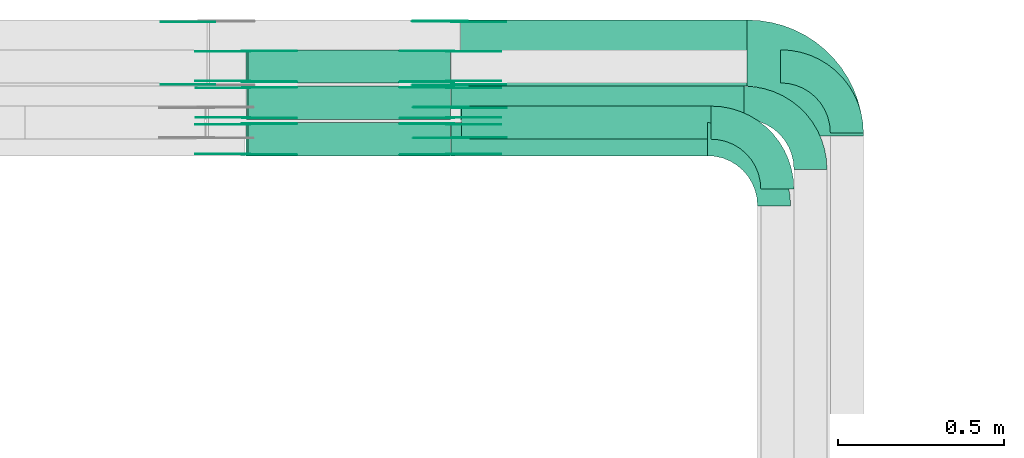
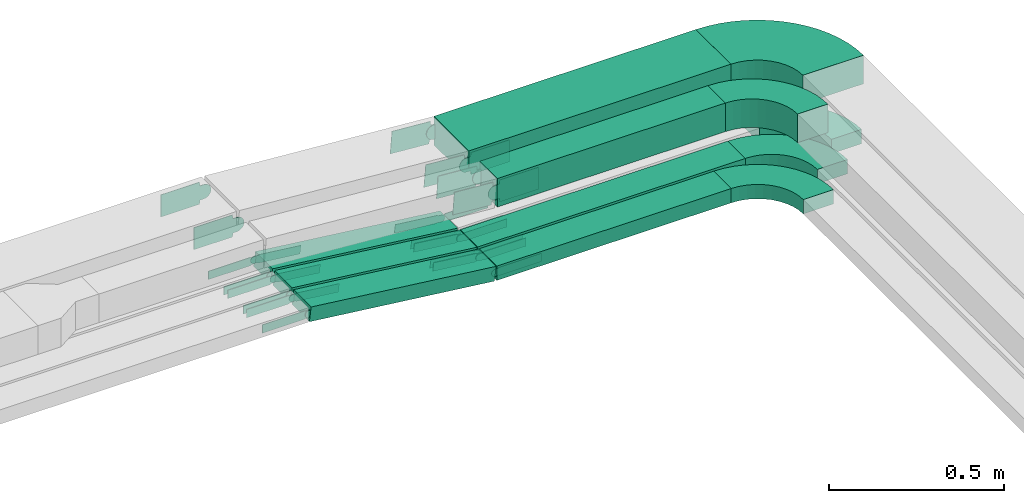
# One storey, part 22 of 23: 39 flow fittings, 7 flow segments.
"""IFC2X3 building model written with IfcOpenShell, lengths in millimetres."""

from ifc_helpers import new_model, entity, si_unit, converted_unit, derived_unit, direction, frame, frame_2d, origin, origin_2d_with_axis, place, context, subcontext, project, spatial, polyline, circle_curve, parameter, trimmed, segment, composite_curve, rectangle, outline, extrude, source, transform, mapped, material, type_object, type_shapes, element, save


model = new_model("IFC2X3")

# Units and contexts
model_context = context("Model", 3, precision=0.01, world=origin(), true_north=direction((6.12303176911189e-17, 1.0)))
body_context = subcontext(model_context, "Body", "Model", "MODEL_VIEW")
ifc_project = project(units=[si_unit("LENGTHUNIT", "METRE", prefix="MILLI"), si_unit("AREAUNIT", "SQUARE_METRE"), si_unit("VOLUMEUNIT", "CUBIC_METRE"), converted_unit("PLANEANGLEUNIT", "DEGREE", entity("IfcRatioMeasure", 0.0174532925199433), si_unit("PLANEANGLEUNIT", "RADIAN"), dimensions=[0, 0, 0, 0, 0, 0, 0]), si_unit("MASSUNIT", "GRAM", prefix="KILO"), derived_unit("MASSDENSITYUNIT", [(si_unit("MASSUNIT", "GRAM", prefix="KILO"), 1), (si_unit("LENGTHUNIT", "METRE"), -3)]), derived_unit("MOMENTOFINERTIAUNIT", [(si_unit("LENGTHUNIT", "METRE"), 4)]), si_unit("TIMEUNIT", "SECOND"), si_unit("FREQUENCYUNIT", "HERTZ"), si_unit("THERMODYNAMICTEMPERATUREUNIT", "DEGREE_CELSIUS"), derived_unit("THERMALTRANSMITTANCEUNIT", [(si_unit("MASSUNIT", "GRAM", prefix="KILO"), 1), (si_unit("THERMODYNAMICTEMPERATUREUNIT", "KELVIN"), -1), (si_unit("TIMEUNIT", "SECOND"), -3)]), derived_unit("VOLUMETRICFLOWRATEUNIT", [(si_unit("LENGTHUNIT", "METRE"), 3), (si_unit("TIMEUNIT", "SECOND"), -1)]), derived_unit("MASSFLOWRATEUNIT", [(si_unit("MASSUNIT", "GRAM", prefix="KILO"), 1), (si_unit("TIMEUNIT", "SECOND"), -1)]), derived_unit("ROTATIONALFREQUENCYUNIT", [(si_unit("TIMEUNIT", "SECOND"), -1)]), si_unit("ELECTRICCURRENTUNIT", "AMPERE"), si_unit("ELECTRICVOLTAGEUNIT", "VOLT"), si_unit("POWERUNIT", "WATT"), si_unit("FORCEUNIT", "NEWTON", prefix="KILO"), si_unit("ILLUMINANCEUNIT", "LUX"), si_unit("LUMINOUSFLUXUNIT", "LUMEN"), si_unit("LUMINOUSINTENSITYUNIT", "CANDELA"), derived_unit("USERDEFINED", [(si_unit("MASSUNIT", "GRAM", prefix="KILO"), -1), (si_unit("LENGTHUNIT", "METRE"), -2), (si_unit("TIMEUNIT", "SECOND"), 3), (si_unit("LUMINOUSFLUXUNIT", "LUMEN"), 1)]), derived_unit("LINEARVELOCITYUNIT", [(si_unit("LENGTHUNIT", "METRE"), 1), (si_unit("TIMEUNIT", "SECOND"), -1)]), si_unit("PRESSUREUNIT", "PASCAL"), derived_unit("USERDEFINED", [(si_unit("LENGTHUNIT", "METRE"), -2), (si_unit("MASSUNIT", "GRAM", prefix="KILO"), 1), (si_unit("TIMEUNIT", "SECOND"), -2)]), derived_unit("LINEARFORCEUNIT", [(si_unit("MASSUNIT", "GRAM", prefix="KILO"), 1), (si_unit("LENGTHUNIT", "METRE"), 1), (si_unit("TIMEUNIT", "SECOND"), -2), (si_unit("LENGTHUNIT", "METRE"), -1)]), derived_unit("PLANARFORCEUNIT", [(si_unit("MASSUNIT", "GRAM", prefix="KILO"), 1), (si_unit("LENGTHUNIT", "METRE"), 1), (si_unit("TIMEUNIT", "SECOND"), -2), (si_unit("LENGTHUNIT", "METRE"), -2)])], contexts=[model_context])

# Site, building, storey
site_placement = place(None, origin())
site = spatial("IfcSite", under=ifc_project, at=site_placement, CompositionType="ELEMENT")
building_placement = place(site_placement, origin())
building = spatial("IfcBuilding", under=site, at=building_placement, CompositionType="ELEMENT")
storey_placement = place(building_placement, frame((0.0, 0.0, 24000.0)))
storey = spatial("IfcBuildingStorey", under=building, at=storey_placement, CompositionType="ELEMENT", Elevation=24000.0)

# Flow segments
cable_carrier_segment_type = type_object("IfcCableCarrierSegmentType", PredefinedType="CABLETRAYSEGMENT")
flow_segment_1_placement = place(storey_placement, frame((63984.79, 18810.0, 2972.83)))
element("IfcFlowSegment", 1, at=flow_segment_1_placement, inside=storey, type_object=cable_carrier_segment_type, context=body_context, shape_type="SweptSolid", body=[
    extrude(rectangle(XDim=884.28828783733, YDim=99.9999999999989, at=origin_2d_with_axis()), frame((442.14, 50.0, 0.0), z_axis=(0.0, 0.0, 1.0), x_axis=(-1.0, 0.0, 0.0)), (0.0, 0.0, 1.0), 49.9999999999973),
])
flow_segment_2_placement = place(storey_placement, frame((63984.79, 18700.0, 2972.83)))
element("IfcFlowSegment", 2, at=flow_segment_2_placement, inside=storey, type_object=cable_carrier_segment_type, context=body_context, shape_type="SweptSolid", body=[
    extrude(rectangle(XDim=774.292459002087, YDim=99.9999999999989, at=origin_2d_with_axis()), frame((387.15, 50.0, 0.0), z_axis=(0.0, 0.0, 1.0), x_axis=(-1.0, 0.0, 0.0)), (0.0, 0.0, 1.0), 49.9999999999973),
])
flow_segment_3_placement = place(storey_placement, frame((64013.12, 18910.0, 3187.83)))
element("IfcFlowSegment", 3, at=flow_segment_3_placement, inside=storey, type_object=cable_carrier_segment_type, context=body_context, shape_type="SweptSolid", body=[
    extrude(rectangle(XDim=865.961742419888, YDim=199.999999999998, at=origin_2d_with_axis()), frame((432.98, 100.0, 0.0), z_axis=(0.0, 0.0, 1.0), x_axis=(-1.0, 0.0, 0.0)), (0.0, 0.0, 1.0), 100.000000000003),
])
flow_segment_4_placement = place(storey_placement, frame((64015.61, 18750.0, 3187.83)))
element("IfcFlowSegment", 4, at=flow_segment_4_placement, inside=storey, type_object=cable_carrier_segment_type, context=body_context, shape_type="SweptSolid", body=[
    extrude(rectangle(XDim=753.47142261159, YDim=99.9999999999989, at=origin_2d_with_axis()), frame((376.74, 50.0, 0.0), z_axis=(0.0, 0.0, 1.0), x_axis=(-1.0, 0.0, 0.0)), (0.0, 0.0, 1.0), 100.000000000003),
])
flow_segment_5_placement = place(storey_placement, frame((63365.28, 18700.0, 2973.31)))
element("IfcFlowSegment", 5, at=flow_segment_5_placement, inside=storey, type_object=cable_carrier_segment_type, context=body_context, shape_type="SweptSolid", body=[
    extrude(rectangle(XDim=49.9999999999981, YDim=99.9999999999989, at=origin_2d_with_axis()), frame((2.92, 50.0, 96.77), z_axis=(0.993143370179474, 0.0, -0.116902721390724), x_axis=(0.116902721390724, 0.0, 0.993143370179474)), (0.0, 0.0, 1.0), 615.423397465658),
])
flow_segment_6_placement = place(storey_placement, frame((63366.23, 18810.0, 2973.32)))
element("IfcFlowSegment", 6, at=flow_segment_6_placement, inside=storey, type_object=cable_carrier_segment_type, context=body_context, shape_type="SweptSolid", body=[
    extrude(rectangle(XDim=50.0000000000043, YDim=99.9999999999989, at=origin_2d_with_axis()), frame((2.93, 50.0, 96.77), z_axis=(0.993122412761879, 0.0, -0.117080627219125), x_axis=(0.117080627219125, 0.0, 0.993122412761879)), (0.0, 0.0, 1.0), 614.474831048791),
])
flow_segment_7_placement = place(storey_placement, frame((63365.28, 18920.0, 2973.31)))
element("IfcFlowSegment", 7, at=flow_segment_7_placement, inside=storey, type_object=cable_carrier_segment_type, context=body_context, shape_type="SweptSolid", body=[
    extrude(rectangle(XDim=49.9999999999981, YDim=99.9999999999989, at=origin_2d_with_axis()), frame((2.92, 50.0, 96.77), z_axis=(0.993143370179474, 0.0, -0.116902721390724), x_axis=(0.116902721390724, 0.0, 0.993143370179474)), (0.0, 0.0, 1.0), 615.42339746565),
])

# Flow fittings
ifc_material_1 = material()
cable_carrier_fitting_type_1 = type_object("IfcCableCarrierFittingType", Name="470_DKC_S5_Variable Angle Elbow 0-45:-", PredefinedType="NOTDEFINED", material=ifc_material_1)
shared_shape_1 = source(origin(), body_context, "Body", "SweptSolid", [
    extrude(outline(composite_curve([segment(polyline([(-125.75, -225.25), (-124.75, -225.25)]), True, "CONTINUOUS"), segment(trimmed(circle_curve(frame_2d((-124.75, 124.75), x_axis=(0.0, -1.0)), 350.0), [parameter(0.0)], [parameter(90.0000000000001)], True, "PARAMETER"), True, "CONTINUOUS"), segment(polyline([(225.25, 124.75), (225.25, 125.75)]), True, "CONTINUOUS"), segment(polyline([(225.25, 125.75), (25.25, 125.75)]), True, "CONTINUOUS"), segment(polyline([(25.25, 125.75), (25.25, 124.75)]), True, "CONTINUOUS"), segment(trimmed(circle_curve(frame_2d((-124.75, 124.75), x_axis=(0.0, -1.0)), 150.0), [parameter(0.0)], [parameter(90.0000000000001)], True, "PARAMETER"), False, "CONTINUOUS"), segment(polyline([(-124.75, -25.25), (-125.75, -25.25)]), True, "CONTINUOUS"), segment(polyline([(-125.75, -25.25), (-125.75, -225.25)]), True, "CONTINUOUS")], self_intersect=False)), frame((-125.25, 125.25, -50.0)), (0.0, 0.0, 1.0), 100.0),
])
type_shapes(cable_carrier_fitting_type_1, [shared_shape_1])
flow_fitting_1_placement = place(storey_placement, frame((65130.08, 19010.0, 3237.83), z_axis=(0.0, 0.0, 1.0), x_axis=(0.0, 1.0, 0.0)))
element("IfcFlowFitting", 8, at=flow_fitting_1_placement, inside=storey, type_object=cable_carrier_fitting_type_1, material=ifc_material_1, Name="470_DKC_S5_Variable Angle Elbow 0-45:-", ObjectType="470_DKC_S5_Variable Angle Elbow 0-45:-", context=body_context, shape_type="MappedRepresentation", body=[
    mapped(shared_shape_1, transform((0.0, 0.0, 0.0), scale=1.0)),
])
cable_carrier_fitting_type_2 = type_object("IfcCableCarrierFittingType", Name="470_DKC_S5_Variable Angle Elbow 0-45:-", PredefinedType="NOTDEFINED", material=ifc_material_1)
shared_shape_2 = source(origin(), body_context, "Body", "SweptSolid", [
    extrude(outline(composite_curve([segment(polyline([(-100.75, -150.25), (-99.75, -150.25)]), True, "CONTINUOUS"), segment(trimmed(circle_curve(frame_2d((-99.75, 99.75), x_axis=(0.0, -1.0)), 250.0), [parameter(0.0)], [parameter(90.0000000000001)], True, "PARAMETER"), True, "CONTINUOUS"), segment(polyline([(150.25, 99.75), (150.25, 100.75)]), True, "CONTINUOUS"), segment(polyline([(150.25, 100.75), (50.25, 100.75)]), True, "CONTINUOUS"), segment(polyline([(50.25, 100.75), (50.25, 99.75)]), True, "CONTINUOUS"), segment(trimmed(circle_curve(frame_2d((-99.75, 99.75), x_axis=(0.0, -1.0)), 150.0), [parameter(0.0)], [parameter(90.0000000000001)], True, "PARAMETER"), False, "CONTINUOUS"), segment(polyline([(-99.75, -50.25), (-100.75, -50.25)]), True, "CONTINUOUS"), segment(polyline([(-100.75, -50.25), (-100.75, -150.25)]), True, "CONTINUOUS")], self_intersect=False)), frame((-100.25, 100.25, -25.0)), (0.0, 0.0, 1.0), 49.9999999999997),
])
type_shapes(cable_carrier_fitting_type_2, [shared_shape_2])
for number, where, z_axis, x_axis, name in (
    (9, (65180.08, 18970.0, 2997.83), (0.0, 0.0, 1.0), (0.0, 1.0, 0.0), "470_DKC_S5_Variable Angle Elbow 0-45:-"),
    (10, (65070.08, 18860.0, 2997.83), (0.0, 0.0, 1.0), (0.0, 1.0, 0.0), "470_DKC_S5_Variable Angle Elbow 0-45:-"),
    (11, (64960.08, 18750.0, 2997.83), (0.0, 0.0, 1.0), (0.0, 1.0, 0.0), "470_DKC_S5_Variable Angle Elbow 0-45:-"),
):
    element("IfcFlowFitting", number, at=place(storey_placement, frame(where, z_axis=z_axis, x_axis=x_axis)), inside=storey, type_object=cable_carrier_fitting_type_2, material=ifc_material_1, Name=name, ObjectType="470_DKC_S5_Variable Angle Elbow 0-45:-", context=body_context, shape_type="MappedRepresentation", body=[
        mapped(shared_shape_2, transform((0.0, 0.0, 0.0), scale=1.0)),
    ])
ifc_material_2 = material(Name="G")
cable_carrier_fitting_type_3 = type_object("IfcCableCarrierFittingType", PredefinedType="NOTDEFINED", material=ifc_material_2)
shared_shape_3 = source(origin(), body_context, "Body", "SweptSolid", [
    extrude(outline(composite_curve([segment(trimmed(circle_curve(frame_2d((-44.59, 0.0), x_axis=(1.0, 0.0)), 12.5), [parameter(90.0000000000007)], [parameter(270.0)], True, "PARAMETER"), True, "CONTINUOUS"), segment(polyline([(-44.59, -12.5), (-33.09, -12.5)]), True, "CONTINUOUS"), segment(polyline([(-33.09, -12.5), (-31.23, -14.5)]), True, "CONTINUOUS"), segment(polyline([(-31.23, -14.5), (108.91, -14.5)]), True, "CONTINUOUS"), segment(polyline([(108.91, -14.5), (108.91, 14.5)]), True, "CONTINUOUS"), segment(polyline([(108.91, 14.5), (-31.23, 14.5)]), True, "CONTINUOUS"), segment(polyline([(-31.23, 14.5), (-33.09, 12.5)]), True, "CONTINUOUS"), segment(polyline([(-33.09, 12.5), (-44.59, 12.5)]), True, "CONTINUOUS")], self_intersect=False)), frame((44.59, 0.0, 0.0), z_axis=(0.0, 0.0, -1.0), x_axis=(1.0, 0.0, 0.0)), (0.0, 0.0, -1.0), 2.0),
])
type_shapes(cable_carrier_fitting_type_3, [shared_shape_3])
flow_fitting_2_placement = place(storey_placement, frame((63982.09, 18795.46, 2997.83), z_axis=(0.0, 1.0, 0.0), x_axis=(-0.993143370179453, 0.0, 0.1169027213909)))
element("IfcFlowFitting", 12, at=flow_fitting_2_placement, inside=storey, type_object=cable_carrier_fitting_type_3, material=ifc_material_2, context=body_context, shape_type="MappedRepresentation", body=[
    mapped(shared_shape_3, transform((0.0, 0.0, 0.0), scale=1.0)),
])
cable_carrier_fitting_type_4 = type_object("IfcCableCarrierFittingType", PredefinedType="NOTDEFINED", material=ifc_material_2)
type_shapes(cable_carrier_fitting_type_4, [shared_shape_3])
flow_fitting_3_placement = place(storey_placement, frame((63982.09, 18706.54, 2997.83), z_axis=(0.0, -1.0, 0.0), x_axis=(1.0, 0.0, 0.0)))
element("IfcFlowFitting", 13, at=flow_fitting_3_placement, inside=storey, type_object=cable_carrier_fitting_type_4, material=ifc_material_2, context=body_context, shape_type="MappedRepresentation", body=[
    mapped(shared_shape_3, transform((0.0, 0.0, 0.0), scale=1.0)),
])
flow_fitting_4_placement = place(storey_placement, frame((63365.52, 18795.46, 3070.4), z_axis=(0.0, 1.0, 0.0), x_axis=(0.993143370179453, 0.0, -0.1169027213909)))
element("IfcFlowFitting", 14, at=flow_fitting_4_placement, inside=storey, type_object=cable_carrier_fitting_type_3, material=ifc_material_2, context=body_context, shape_type="MappedRepresentation", body=[
    mapped(shared_shape_3, transform((0.0, 0.0, 0.0), scale=1.0)),
])
flow_fitting_5_placement = place(storey_placement, frame((63365.52, 18706.54, 3070.4), z_axis=(0.0, -1.0, 0.0), x_axis=(-1.0, 0.0, 0.0)))
element("IfcFlowFitting", 15, at=flow_fitting_5_placement, inside=storey, type_object=cable_carrier_fitting_type_4, material=ifc_material_2, context=body_context, shape_type="MappedRepresentation", body=[
    mapped(shared_shape_3, transform((0.0, 0.0, 0.0), scale=1.0)),
])
flow_fitting_6_placement = place(storey_placement, frame((63982.09, 18905.46, 2997.83), z_axis=(0.0, 1.0, 0.0), x_axis=(-0.993122412761891, 0.0, 0.117080627219026)))
element("IfcFlowFitting", 16, at=flow_fitting_6_placement, inside=storey, type_object=cable_carrier_fitting_type_3, material=ifc_material_2, context=body_context, shape_type="MappedRepresentation", body=[
    mapped(shared_shape_3, transform((0.0, 0.0, 0.0), scale=1.0)),
])
flow_fitting_7_placement = place(storey_placement, frame((63982.09, 18816.54, 2997.83), z_axis=(0.0, -1.0, 0.0), x_axis=(1.0, 0.0, 0.0)))
element("IfcFlowFitting", 17, at=flow_fitting_7_placement, inside=storey, type_object=cable_carrier_fitting_type_4, material=ifc_material_2, context=body_context, shape_type="MappedRepresentation", body=[
    mapped(shared_shape_3, transform((0.0, 0.0, 0.0), scale=1.0)),
])
flow_fitting_8_placement = place(storey_placement, frame((63366.47, 18905.46, 3070.4), z_axis=(0.0, 1.0, 0.0), x_axis=(0.993122412761891, 0.0, -0.117080627219026)))
element("IfcFlowFitting", 18, at=flow_fitting_8_placement, inside=storey, type_object=cable_carrier_fitting_type_3, material=ifc_material_2, context=body_context, shape_type="MappedRepresentation", body=[
    mapped(shared_shape_3, transform((0.0, 0.0, 0.0), scale=1.0)),
])
flow_fitting_9_placement = place(storey_placement, frame((63366.47, 18816.54, 3070.4), z_axis=(0.0, -1.0, 0.0), x_axis=(-1.0, 0.0, 0.0)))
element("IfcFlowFitting", 19, at=flow_fitting_9_placement, inside=storey, type_object=cable_carrier_fitting_type_4, material=ifc_material_2, context=body_context, shape_type="MappedRepresentation", body=[
    mapped(shared_shape_3, transform((0.0, 0.0, 0.0), scale=1.0)),
])
flow_fitting_10_placement = place(storey_placement, frame((63982.09, 19015.46, 2997.83), z_axis=(0.0, 1.0, 0.0), x_axis=(-0.993143370179453, 0.0, 0.1169027213909)))
element("IfcFlowFitting", 20, at=flow_fitting_10_placement, inside=storey, type_object=cable_carrier_fitting_type_3, material=ifc_material_2, context=body_context, shape_type="MappedRepresentation", body=[
    mapped(shared_shape_3, transform((0.0, 0.0, 0.0), scale=1.0)),
])
flow_fitting_11_placement = place(storey_placement, frame((63982.09, 18926.54, 2997.83), z_axis=(0.0, -1.0, 0.0), x_axis=(1.0, 0.0, 0.0)))
element("IfcFlowFitting", 21, at=flow_fitting_11_placement, inside=storey, type_object=cable_carrier_fitting_type_4, material=ifc_material_2, context=body_context, shape_type="MappedRepresentation", body=[
    mapped(shared_shape_3, transform((0.0, 0.0, 0.0), scale=1.0)),
])
flow_fitting_12_placement = place(storey_placement, frame((63365.52, 19015.46, 3070.4), z_axis=(0.0, 1.0, 0.0), x_axis=(0.993143370179453, 0.0, -0.1169027213909)))
element("IfcFlowFitting", 22, at=flow_fitting_12_placement, inside=storey, type_object=cable_carrier_fitting_type_3, material=ifc_material_2, context=body_context, shape_type="MappedRepresentation", body=[
    mapped(shared_shape_3, transform((0.0, 0.0, 0.0), scale=1.0)),
])
flow_fitting_13_placement = place(storey_placement, frame((63365.52, 18926.54, 3070.4), z_axis=(0.0, -1.0, 0.0), x_axis=(-1.0, 0.0, 0.0)))
element("IfcFlowFitting", 23, at=flow_fitting_13_placement, inside=storey, type_object=cable_carrier_fitting_type_4, material=ifc_material_2, context=body_context, shape_type="MappedRepresentation", body=[
    mapped(shared_shape_3, transform((0.0, 0.0, 0.0), scale=1.0)),
])
cable_carrier_fitting_type_5 = type_object("IfcCableCarrierFittingType", PredefinedType="NOTDEFINED", material=ifc_material_2)
shared_shape_4 = source(origin(), body_context, "Body", "SweptSolid", [
    extrude(outline(composite_curve([segment(trimmed(circle_curve(frame_2d((-44.59, 0.0), x_axis=(1.0, 0.0)), 12.5), [parameter(90.0000000000007)], [parameter(270.0)], True, "PARAMETER"), True, "CONTINUOUS"), segment(polyline([(-44.59, -12.5), (-33.09, -12.5)]), True, "CONTINUOUS"), segment(polyline([(-33.09, -12.5), (-31.23, -14.5)]), True, "CONTINUOUS"), segment(polyline([(-31.23, -14.5), (108.91, -14.5)]), True, "CONTINUOUS"), segment(polyline([(108.91, -14.5), (108.91, 14.5)]), True, "CONTINUOUS"), segment(polyline([(108.91, 14.5), (-31.23, 14.5)]), True, "CONTINUOUS"), segment(polyline([(-31.23, 14.5), (-33.09, 12.5)]), True, "CONTINUOUS"), segment(polyline([(-33.09, 12.5), (-44.59, 12.5)]), True, "CONTINUOUS")], self_intersect=False)), frame((44.59, 0.0, 0.0)), (0.0, 0.0, 1.0), 2.0),
])
type_shapes(cable_carrier_fitting_type_5, [shared_shape_4])
flow_fitting_14_placement = place(storey_placement, frame((63982.09, 18704.54, 2997.83), z_axis=(0.0, -1.0, 0.0), x_axis=(-0.993143370179453, 0.0, 0.1169027213909)))
element("IfcFlowFitting", 24, at=flow_fitting_14_placement, inside=storey, type_object=cable_carrier_fitting_type_5, material=ifc_material_2, context=body_context, shape_type="MappedRepresentation", body=[
    mapped(shared_shape_4, transform((0.0, 0.0, 0.0), scale=1.0)),
])
cable_carrier_fitting_type_6 = type_object("IfcCableCarrierFittingType", PredefinedType="NOTDEFINED", material=ifc_material_2)
type_shapes(cable_carrier_fitting_type_6, [shared_shape_4])
flow_fitting_15_placement = place(storey_placement, frame((63982.09, 18793.46, 2997.83), z_axis=(0.0, 1.0, 0.0), x_axis=(1.0, 0.0, 0.0)))
element("IfcFlowFitting", 25, at=flow_fitting_15_placement, inside=storey, type_object=cable_carrier_fitting_type_6, material=ifc_material_2, context=body_context, shape_type="MappedRepresentation", body=[
    mapped(shared_shape_4, transform((0.0, 0.0, 0.0), scale=1.0)),
])
flow_fitting_16_placement = place(storey_placement, frame((63365.52, 18704.54, 3070.4), z_axis=(0.0, -1.0, 0.0), x_axis=(0.993143370179453, 0.0, -0.1169027213909)))
element("IfcFlowFitting", 26, at=flow_fitting_16_placement, inside=storey, type_object=cable_carrier_fitting_type_5, material=ifc_material_2, context=body_context, shape_type="MappedRepresentation", body=[
    mapped(shared_shape_4, transform((0.0, 0.0, 0.0), scale=1.0)),
])
flow_fitting_17_placement = place(storey_placement, frame((63365.52, 18793.46, 3070.4), z_axis=(0.0, 1.0, 0.0), x_axis=(-1.0, 0.0, 0.0)))
element("IfcFlowFitting", 27, at=flow_fitting_17_placement, inside=storey, type_object=cable_carrier_fitting_type_6, material=ifc_material_2, context=body_context, shape_type="MappedRepresentation", body=[
    mapped(shared_shape_4, transform((0.0, 0.0, 0.0), scale=1.0)),
])
flow_fitting_18_placement = place(storey_placement, frame((63982.09, 18814.54, 2997.83), z_axis=(0.0, -1.0, 0.0), x_axis=(-0.993122412761891, 0.0, 0.117080627219026)))
element("IfcFlowFitting", 28, at=flow_fitting_18_placement, inside=storey, type_object=cable_carrier_fitting_type_5, material=ifc_material_2, context=body_context, shape_type="MappedRepresentation", body=[
    mapped(shared_shape_4, transform((0.0, 0.0, 0.0), scale=1.0)),
])
flow_fitting_19_placement = place(storey_placement, frame((63982.09, 18903.46, 2997.83), z_axis=(0.0, 1.0, 0.0), x_axis=(1.0, 0.0, 0.0)))
element("IfcFlowFitting", 29, at=flow_fitting_19_placement, inside=storey, type_object=cable_carrier_fitting_type_6, material=ifc_material_2, context=body_context, shape_type="MappedRepresentation", body=[
    mapped(shared_shape_4, transform((0.0, 0.0, 0.0), scale=1.0)),
])
flow_fitting_20_placement = place(storey_placement, frame((63366.47, 18814.54, 3070.4), z_axis=(0.0, -1.0, 0.0), x_axis=(0.993122412761891, 0.0, -0.117080627219026)))
element("IfcFlowFitting", 30, at=flow_fitting_20_placement, inside=storey, type_object=cable_carrier_fitting_type_5, material=ifc_material_2, context=body_context, shape_type="MappedRepresentation", body=[
    mapped(shared_shape_4, transform((0.0, 0.0, 0.0), scale=1.0)),
])
flow_fitting_21_placement = place(storey_placement, frame((63366.47, 18903.46, 3070.4), z_axis=(0.0, 1.0, 0.0), x_axis=(-1.0, 0.0, 0.0)))
element("IfcFlowFitting", 31, at=flow_fitting_21_placement, inside=storey, type_object=cable_carrier_fitting_type_6, material=ifc_material_2, context=body_context, shape_type="MappedRepresentation", body=[
    mapped(shared_shape_4, transform((0.0, 0.0, 0.0), scale=1.0)),
])
flow_fitting_22_placement = place(storey_placement, frame((63982.09, 18924.54, 2997.83), z_axis=(0.0, -1.0, 0.0), x_axis=(-0.993143370179453, 0.0, 0.1169027213909)))
element("IfcFlowFitting", 32, at=flow_fitting_22_placement, inside=storey, type_object=cable_carrier_fitting_type_5, material=ifc_material_2, context=body_context, shape_type="MappedRepresentation", body=[
    mapped(shared_shape_4, transform((0.0, 0.0, 0.0), scale=1.0)),
])
flow_fitting_23_placement = place(storey_placement, frame((63982.09, 19013.46, 2997.83), z_axis=(0.0, 1.0, 0.0), x_axis=(1.0, 0.0, 0.0)))
element("IfcFlowFitting", 33, at=flow_fitting_23_placement, inside=storey, type_object=cable_carrier_fitting_type_6, material=ifc_material_2, context=body_context, shape_type="MappedRepresentation", body=[
    mapped(shared_shape_4, transform((0.0, 0.0, 0.0), scale=1.0)),
])
flow_fitting_24_placement = place(storey_placement, frame((63365.52, 18924.54, 3070.4), z_axis=(0.0, -1.0, 0.0), x_axis=(0.993143370179453, 0.0, -0.1169027213909)))
element("IfcFlowFitting", 34, at=flow_fitting_24_placement, inside=storey, type_object=cable_carrier_fitting_type_5, material=ifc_material_2, context=body_context, shape_type="MappedRepresentation", body=[
    mapped(shared_shape_4, transform((0.0, 0.0, 0.0), scale=1.0)),
])
flow_fitting_25_placement = place(storey_placement, frame((63365.52, 19013.46, 3070.4), z_axis=(0.0, 1.0, 0.0), x_axis=(-1.0, 0.0, 0.0)))
element("IfcFlowFitting", 35, at=flow_fitting_25_placement, inside=storey, type_object=cable_carrier_fitting_type_6, material=ifc_material_2, context=body_context, shape_type="MappedRepresentation", body=[
    mapped(shared_shape_4, transform((0.0, 0.0, 0.0), scale=1.0)),
])
cable_carrier_fitting_type_7 = type_object("IfcCableCarrierFittingType", Name="470_DKC_S5_Variable Angle Elbow 0-45:-", PredefinedType="NOTDEFINED", material=ifc_material_1)
shared_shape_5 = source(origin(), body_context, "Body", "SweptSolid", [
    extrude(outline(composite_curve([segment(polyline([(-100.75, -150.25), (-99.75, -150.25)]), True, "CONTINUOUS"), segment(trimmed(circle_curve(frame_2d((-99.75, 99.75), x_axis=(0.0, -1.0)), 250.0), [parameter(0.0)], [parameter(90.0000000000001)], True, "PARAMETER"), True, "CONTINUOUS"), segment(polyline([(150.25, 99.75), (150.25, 100.75)]), True, "CONTINUOUS"), segment(polyline([(150.25, 100.75), (50.25, 100.75)]), True, "CONTINUOUS"), segment(polyline([(50.25, 100.75), (50.25, 99.75)]), True, "CONTINUOUS"), segment(trimmed(circle_curve(frame_2d((-99.75, 99.75), x_axis=(0.0, -1.0)), 150.0), [parameter(0.0)], [parameter(90.0000000000001)], True, "PARAMETER"), False, "CONTINUOUS"), segment(polyline([(-99.75, -50.25), (-100.75, -50.25)]), True, "CONTINUOUS"), segment(polyline([(-100.75, -50.25), (-100.75, -150.25)]), True, "CONTINUOUS")], self_intersect=False)), frame((-100.25, 100.25, -50.0)), (0.0, 0.0, 1.0), 100.0),
])
type_shapes(cable_carrier_fitting_type_7, [shared_shape_5])
flow_fitting_26_placement = place(storey_placement, frame((64970.08, 18800.0, 3237.83), z_axis=(0.0, 0.0, 1.0), x_axis=(0.0, 1.0, 0.0)))
element("IfcFlowFitting", 36, at=flow_fitting_26_placement, inside=storey, type_object=cable_carrier_fitting_type_7, material=ifc_material_1, Name="470_DKC_S5_Variable Angle Elbow 0-45:-", ObjectType="470_DKC_S5_Variable Angle Elbow 0-45:-", context=body_context, shape_type="MappedRepresentation", body=[
    mapped(shared_shape_5, transform((0.0, 0.0, 0.0), scale=1.0)),
])
cable_carrier_fitting_type_8 = type_object("IfcCableCarrierFittingType", PredefinedType="NOTDEFINED", material=ifc_material_2)
shared_shape_6 = source(origin(), body_context, "Body", "SweptSolid", [
    extrude(outline(composite_curve([segment(trimmed(circle_curve(frame_2d((-41.47, 0.0), x_axis=(1.0, 0.0)), 25.0), [parameter(90.0000000000007)], [parameter(270.0)], True, "PARAMETER"), True, "CONTINUOUS"), segment(polyline([(-41.47, -25.0), (-29.97, -25.0)]), True, "CONTINUOUS"), segment(polyline([(-29.97, -25.0), (-28.1, -38.5)]), True, "CONTINUOUS"), segment(polyline([(-28.1, -38.5), (99.53, -38.5)]), True, "CONTINUOUS"), segment(polyline([(99.53, -38.5), (99.53, 38.5)]), True, "CONTINUOUS"), segment(polyline([(99.53, 38.5), (-28.1, 38.5)]), True, "CONTINUOUS"), segment(polyline([(-28.1, 38.5), (-29.97, 25.0)]), True, "CONTINUOUS"), segment(polyline([(-29.97, 25.0), (-41.47, 25.0)]), True, "CONTINUOUS")], self_intersect=False)), frame((41.47, 0.0, 0.0), z_axis=(0.0, 0.0, -1.0), x_axis=(1.0, 0.0, 0.0)), (0.0, 0.0, -1.0), 2.0),
])
type_shapes(cable_carrier_fitting_type_8, [shared_shape_6])
flow_fitting_27_placement = place(storey_placement, frame((64012.59, 18845.46, 3237.83), z_axis=(0.0, 1.0, 0.0), x_axis=(-0.997198819894238, 0.0, 0.0747964812109387)))
element("IfcFlowFitting", 37, at=flow_fitting_27_placement, inside=storey, type_object=cable_carrier_fitting_type_8, material=ifc_material_2, context=body_context, shape_type="MappedRepresentation", body=[
    mapped(shared_shape_6, transform((0.0, 0.0, 0.0), scale=1.0)),
])
cable_carrier_fitting_type_9 = type_object("IfcCableCarrierFittingType", PredefinedType="NOTDEFINED", material=ifc_material_2)
type_shapes(cable_carrier_fitting_type_9, [shared_shape_6])
flow_fitting_28_placement = place(storey_placement, frame((64012.59, 18756.54, 3237.83), z_axis=(0.0, -1.0, 0.0), x_axis=(1.0, 0.0, 0.0)))
element("IfcFlowFitting", 38, at=flow_fitting_28_placement, inside=storey, type_object=cable_carrier_fitting_type_9, material=ifc_material_2, context=body_context, shape_type="MappedRepresentation", body=[
    mapped(shared_shape_6, transform((0.0, 0.0, 0.0), scale=1.0)),
])
flow_fitting_29_placement = place(storey_placement, frame((64010.08, 19105.46, 3237.83), z_axis=(0.0, 1.0, 0.0), x_axis=(-0.997154606736381, 0.0, 0.075383620663996)))
element("IfcFlowFitting", 39, at=flow_fitting_29_placement, inside=storey, type_object=cable_carrier_fitting_type_8, material=ifc_material_2, context=body_context, shape_type="MappedRepresentation", body=[
    mapped(shared_shape_6, transform((0.0, 0.0, 0.0), scale=1.0)),
])
for number, where, z_axis, x_axis in (
    (40, (64010.08, 18916.54, 3237.83), (0.0, -1.0, 0.0), (1.0, 0.0, 0.0)),
    (41, (63248.48, 18916.54, 3295.4), (0.0, -1.0, 0.0), (-1.0, 0.0, 0.0)),
):
    element("IfcFlowFitting", number, at=place(storey_placement, frame(where, z_axis=z_axis, x_axis=x_axis)), inside=storey, type_object=cable_carrier_fitting_type_9, material=ifc_material_2, context=body_context, shape_type="MappedRepresentation", body=[
        mapped(shared_shape_6, transform((0.0, 0.0, 0.0), scale=1.0)),
    ])
cable_carrier_fitting_type_10 = type_object("IfcCableCarrierFittingType", PredefinedType="NOTDEFINED", material=ifc_material_2)
shared_shape_7 = source(origin(), body_context, "Body", "SweptSolid", [
    extrude(outline(composite_curve([segment(trimmed(circle_curve(frame_2d((-41.47, 0.0), x_axis=(1.0, 0.0)), 25.0), [parameter(90.0000000000007)], [parameter(270.0)], True, "PARAMETER"), True, "CONTINUOUS"), segment(polyline([(-41.47, -25.0), (-29.97, -25.0)]), True, "CONTINUOUS"), segment(polyline([(-29.97, -25.0), (-28.1, -38.5)]), True, "CONTINUOUS"), segment(polyline([(-28.1, -38.5), (99.53, -38.5)]), True, "CONTINUOUS"), segment(polyline([(99.53, -38.5), (99.53, 38.5)]), True, "CONTINUOUS"), segment(polyline([(99.53, 38.5), (-28.1, 38.5)]), True, "CONTINUOUS"), segment(polyline([(-28.1, 38.5), (-29.97, 25.0)]), True, "CONTINUOUS"), segment(polyline([(-29.97, 25.0), (-41.47, 25.0)]), True, "CONTINUOUS")], self_intersect=False)), frame((41.47, 0.0, 0.0)), (0.0, 0.0, 1.0), 2.0),
])
type_shapes(cable_carrier_fitting_type_10, [shared_shape_7])
flow_fitting_30_placement = place(storey_placement, frame((64012.59, 18754.54, 3237.83), z_axis=(0.0, -1.0, 0.0), x_axis=(-0.997198819894238, 0.0, 0.0747964812109387)))
element("IfcFlowFitting", 42, at=flow_fitting_30_placement, inside=storey, type_object=cable_carrier_fitting_type_10, material=ifc_material_2, context=body_context, shape_type="MappedRepresentation", body=[
    mapped(shared_shape_7, transform((0.0, 0.0, 0.0), scale=1.0)),
])
cable_carrier_fitting_type_11 = type_object("IfcCableCarrierFittingType", PredefinedType="NOTDEFINED", material=ifc_material_2)
type_shapes(cable_carrier_fitting_type_11, [shared_shape_7])
flow_fitting_31_placement = place(storey_placement, frame((64012.59, 18843.46, 3237.83), z_axis=(0.0, 1.0, 0.0), x_axis=(1.0, 0.0, 0.0)))
element("IfcFlowFitting", 43, at=flow_fitting_31_placement, inside=storey, type_object=cable_carrier_fitting_type_11, material=ifc_material_2, context=body_context, shape_type="MappedRepresentation", body=[
    mapped(shared_shape_7, transform((0.0, 0.0, 0.0), scale=1.0)),
])
flow_fitting_32_placement = place(storey_placement, frame((64010.08, 18914.54, 3237.83), z_axis=(0.0, -1.0, 0.0), x_axis=(-0.997154606736381, 0.0, 0.075383620663996)))
element("IfcFlowFitting", 44, at=flow_fitting_32_placement, inside=storey, type_object=cable_carrier_fitting_type_10, material=ifc_material_2, context=body_context, shape_type="MappedRepresentation", body=[
    mapped(shared_shape_7, transform((0.0, 0.0, 0.0), scale=1.0)),
])
for number, where, z_axis, x_axis in (
    (45, (64010.08, 19103.46, 3237.83), (0.0, 1.0, 0.0), (1.0, 0.0, 0.0)),
    (46, (63248.48, 19103.46, 3295.4), (0.0, 1.0, 0.0), (-1.0, 0.0, 0.0)),
):
    element("IfcFlowFitting", number, at=place(storey_placement, frame(where, z_axis=z_axis, x_axis=x_axis)), inside=storey, type_object=cable_carrier_fitting_type_11, material=ifc_material_2, context=body_context, shape_type="MappedRepresentation", body=[
        mapped(shared_shape_7, transform((0.0, 0.0, 0.0), scale=1.0)),
    ])

save(model, "model.ifc")
